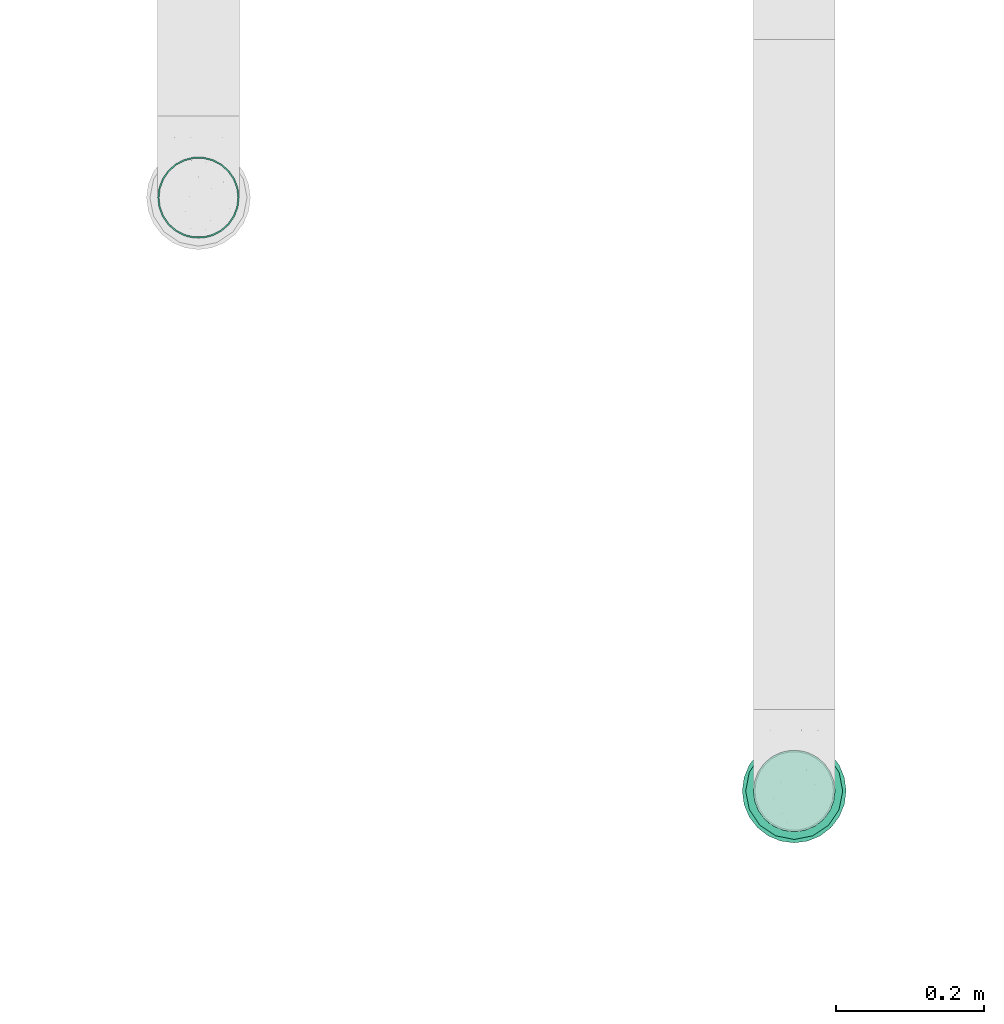
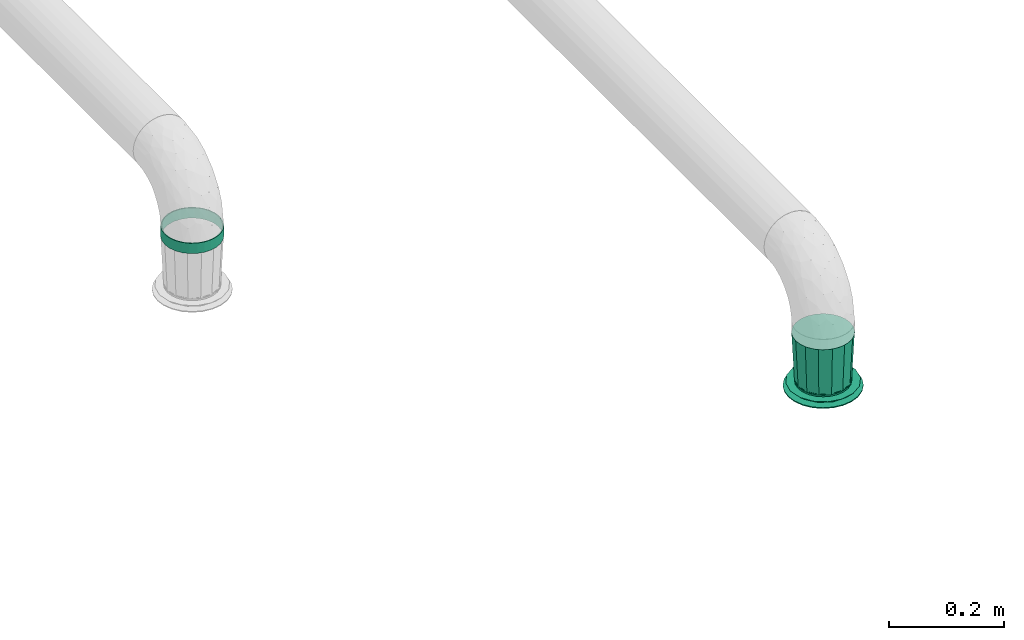
# One storey, part 85 of 123: 1 flow fitting, 1 flow segment, 1 flow terminal.
"""IFC2X3 building model written with IfcOpenShell, lengths in millimetres."""

from ifc_helpers import new_model, entity, si_unit, converted_unit, derived_unit, direction, frame, origin_with_axes, origin_2d_with_axis, place, context, subcontext, project, spatial, hollow_circle, extrude, open_shell, surface_model, source, transform, mapped, material, layer, layer_set, layer_usage, type_object, element, save


model = new_model("IFC2X3")

# Units and contexts
model_context = context("Model", 3, precision=1e-05, world=origin_with_axes(), true_north=direction((0.0, 1.0)))
body_context = subcontext(model_context, "Body", "Model", "MODEL_VIEW")
ifc_project = project(units=[si_unit("AREAUNIT", "SQUARE_METRE"), si_unit("VOLUMEUNIT", "CUBIC_METRE", prefix="DECI"), si_unit("TIMEUNIT", "SECOND"), si_unit("THERMODYNAMICTEMPERATUREUNIT", "DEGREE_CELSIUS"), si_unit("PRESSUREUNIT", "PASCAL"), si_unit("MASSUNIT", "GRAM", prefix="KILO"), si_unit("LENGTHUNIT", "METRE", prefix="MILLI"), si_unit("POWERUNIT", "WATT"), si_unit("ELECTRICCURRENTUNIT", "AMPERE"), si_unit("ELECTRICVOLTAGEUNIT", "VOLT"), derived_unit("VOLUMETRICFLOWRATEUNIT", [(si_unit("VOLUMEUNIT", "CUBIC_METRE", prefix="DECI"), 1), (si_unit("TIMEUNIT", "SECOND"), -1)]), derived_unit("LINEARVELOCITYUNIT", [(si_unit("LENGTHUNIT", "METRE"), 1), (si_unit("TIMEUNIT", "SECOND"), -1)]), derived_unit("MASSDENSITYUNIT", [(si_unit("MASSUNIT", "GRAM", prefix="KILO"), 1), (si_unit("VOLUMEUNIT", "CUBIC_METRE"), -1)]), converted_unit("PLANEANGLEUNIT", "DEGREE", entity("IfcRatioMeasure", 0.01745), si_unit("PLANEANGLEUNIT", "RADIAN"), dimensions=[0, 0, 0, 0, 0, 0, 0])], contexts=[model_context])

# Site, building, storey
site_placement = place(None, origin_with_axes())
site = spatial("IfcSite", under=ifc_project, at=site_placement, CompositionType="ELEMENT")
building_placement = place(site_placement, origin_with_axes())
building = spatial("IfcBuilding", under=site, at=building_placement, Name="mc-building", CompositionType="ELEMENT")
storey_placement = place(building_placement, origin_with_axes())
storey = spatial("IfcBuildingStorey", under=building, at=storey_placement, Name="1. Korrus", CompositionType="ELEMENT", Elevation=0.0)

# Flow segment
ifc_material = material(Name="FZ1")
ifc_layer = layer(ifc_material, 0.0)
ifc_layer_set = layer_set([ifc_layer], Name="FZ1")
ifc_layer_usage = layer_usage(ifc_layer_set, "AXIS1", "POSITIVE", 0.0)
duct_segment_type = type_object("IfcDuctSegmentType", PredefinedType="RIGIDSEGMENT")
shared_shape_1 = source(origin_with_axes(), body_context, "Body", "SweptSolid", [
    extrude(hollow_circle(Radius=55.0, WallThickness=2.0, at=origin_2d_with_axis()), frame((0.0, 0.0, 0.0), z_axis=(1.0, 0.0, 0.0), x_axis=(0.0, 1.0, 0.0)), (0.0, 0.0, 1.0), 21.9),
])
flow_segment_placement = place(storey_placement, frame((18242.77608, 9054.17592, 2325.0), z_axis=(0.0, 1.0, 0.0), x_axis=(0.0, 0.0, -1.0)))
element("IfcFlowSegment", 1, at=flow_segment_placement, inside=storey, type_object=duct_segment_type, material=ifc_layer_usage, context=body_context, shape_type="MappedRepresentation", body=[
    mapped(shared_shape_1, transform((0.0, 0.0, 0.0), scale=1.0)),
])

# Flow terminal
air_terminal_type = type_object("IfcAirTerminalType", Name="100", PredefinedType="NOTDEFINED")
shared_shape_2 = source(origin_with_axes(), body_context, "Body", "SurfaceModel", [
    surface_model("IfcShellBasedSurfaceModel", [(11.2, -70.0, 0.0), (11.2, -67.61481, -18.11733), (11.2, -67.61481, 18.11733), (6.2, -14.64625, -20.15883), (9.2, -22.36867, -22.36867), (6.2, -21.19625, -15.39997), (9.2, 16.375, -28.36233), (6.2, 8.09625, -24.91768), (6.2, 14.64625, -20.15883), (6.2, -8.09625, -24.91768), (9.2, -16.375, -28.36233), (6.2, 21.19625, -15.39997), (9.2, 22.36867, -22.36867), (9.2, -8.1875, -30.55617), (9.2, 8.1875, -30.55617), (9.2, 28.36233, -16.375), (9.2, -28.36233, -16.375), (6.2, 14.64625, 20.15883), (9.2, 22.36867, 22.36867), (6.2, 21.19625, 15.39997), (9.2, -16.375, 28.36233), (6.2, -8.09625, 24.91768), (6.2, -14.64625, 20.15883), (6.2, 8.09625, 24.91768), (9.2, 16.375, 28.36233), (6.2, -21.19625, 15.39997), (9.2, -22.36867, 22.36867), (9.2, 8.1875, 30.55617), (9.2, -8.1875, 30.55617), (9.2, -28.36233, 16.375), (9.2, 28.36233, 16.375), (6.2, -53.11211, -25.57744), (6.2, -36.75472, -46.08897), (6.2, -13.11761, -57.472), (6.2, 13.11761, -57.472), (6.2, 36.75472, -46.08897), (6.2, 53.11211, -25.57744), (0.0, -12.53288, -63.00706), (6.2, 0.0, -57.472), (0.0, -46.3155, -46.3155), (0.0, -35.69063, -53.4148), (0.0, 0.0, -65.5), (6.2, 44.93342, -35.83321), (0.0, 46.3155, -46.3155), (0.0, 35.69063, -53.4148), (6.2, -44.93342, -35.83321), (0.0, 12.53288, -63.00706), (0.0, 25.06576, -60.51411), (6.2, 56.03105, -12.78872), (0.0, 60.51411, -25.06576), (0.0, 63.00706, -12.53288), (0.0, 53.4148, -35.69063), (0.0, -25.06576, -60.51411), (0.0, -63.00706, -12.53288), (0.0, -60.51411, -25.06576), (6.2, -56.03105, -12.78872), (0.0, -53.4148, -35.69063), (6.2, 13.11761, 57.472), (0.0, 12.53288, 63.00706), (6.2, 0.0, 57.472), (6.2, 36.75472, 46.08897), (0.0, 46.3155, 46.3155), (0.0, 35.69063, 53.4148), (0.0, 0.0, 65.5), (6.2, -44.93342, 35.83321), (6.2, -36.75472, 46.08897), (0.0, -46.3155, 46.3155), (0.0, -35.69063, 53.4148), (6.2, 44.93342, 35.83321), (0.0, -12.53288, 63.00706), (0.0, -25.06576, 60.51411), (6.2, -13.11761, 57.472), (6.2, -56.03105, 12.78872), (0.0, -60.51411, 25.06576), (0.0, -63.00706, 12.53288), (0.0, -53.4148, 35.69063), (0.0, 25.06576, 60.51411), (0.0, 63.00706, 12.53288), (0.0, 60.51411, 25.06576), (6.2, 56.03105, 12.78872), (0.0, 53.4148, 35.69063), (-3.1, 43.30127, 25.0), (-3.1, -48.29629, -12.94095), (-3.1, -43.30127, 25.0), (-3.1, 25.0, -43.30127), (-3.1, 48.29629, -12.94095), (-3.1, 35.35534, -35.35534), (-3.1, -35.35534, -35.35534), (-3.1, -25.0, -43.30127), (-43.1, 43.46666, 11.64686), (-3.1, 38.97115, 22.5), (-3.1, 43.46666, 11.64686), (-3.1, 45.0, 0.0), (-43.1, 45.0, 0.0), (-3.1, 31.81981, 31.81981), (-43.1, 38.97115, 22.5), (-43.1, -38.97115, 22.5), (-3.1, -38.97115, 22.5), (-3.1, -31.81981, 31.81981), (-3.1, -43.46666, 11.64686), (-43.1, -43.46666, 11.64686), (-43.1, -45.0, 0.0), (-3.1, -45.0, 0.0), (-43.1, -43.46666, -11.64686), (-3.1, -38.97115, -22.5), (-3.1, -43.46666, -11.64686), (-3.1, -11.64686, -43.46666), (-3.1, -22.5, -38.97115), (-43.1, -22.5, -38.97115), (-3.1, -31.81981, -31.81981), (-43.1, -38.97115, -22.5), (-43.1, 22.5, -38.97115), (-3.1, 22.5, -38.97115), (-3.1, 11.64686, -43.46666), (-43.1, 38.97115, -22.5), (-3.1, 38.97115, -22.5), (-3.1, 31.81981, -31.81981), (-3.1, 43.46666, -11.64686), (-43.1, 43.46666, -11.64686), (11.2, -49.49747, -49.49747), (11.2, -35.0, -60.62178), (11.2, -18.11733, -67.61481), (11.2, 67.61481, 18.11733), (11.2, -60.62178, -35.0), (11.2, 18.11733, -67.61481), (11.2, 35.0, -60.62178), (11.2, 0.0, -70.0), (11.2, 60.62178, -35.0), (11.2, 67.61481, -18.11733), (11.2, 49.49747, -49.49747), (11.2, -49.49747, 49.49747), (11.2, -60.62178, 35.0), (11.2, -35.0, 60.62178), (11.2, -18.11733, 67.61481), (11.2, 0.0, 70.0), (11.2, 60.62178, 35.0), (11.2, 49.49747, 49.49747), (11.2, 70.0, 0.0), (11.2, 35.0, 60.62178), (11.2, 18.11733, 67.61481), (9.2, -49.49747, 49.49747), (9.2, -35.0, 60.62178), (9.2, -18.11733, 67.61481), (9.2, -67.61481, 18.11733), (9.2, -70.0, 0.0), (9.2, -60.62178, 35.0), (9.2, 67.61481, 18.11733), (9.2, 35.0, 60.62178), (9.2, 18.11733, 67.61481), (9.2, 0.0, 70.0), (9.2, 60.62178, 35.0), (9.2, 49.49747, 49.49747), (9.2, -67.61481, -18.11733), (9.2, -49.49747, -49.49747), (9.2, -60.62178, -35.0), (9.2, -18.11733, -67.61481), (9.2, 70.0, 0.0), (9.2, -35.0, -60.62178), (9.2, 0.0, -70.0), (9.2, 60.62178, -35.0), (9.2, 49.49747, -49.49747), (9.2, 67.61481, -18.11733), (9.2, 35.0, -60.62178), (9.2, 18.11733, -67.61481), (9.2, -32.75, 0.0), (9.2, 0.0, 32.75), (9.2, 32.75, 0.0), (9.2, 0.0, -32.75), (6.2, 26.2, 0.0), (6.2, -26.2, 0.0), (9.2, -31.06579, -6.28555), (6.2, -23.69812, -7.69999), (6.2, 23.69812, -7.69999), (9.2, 31.06579, -6.28555), (6.2, 0.0, -24.91768), (9.2, 31.06579, 6.28555), (6.2, 23.69812, 7.69999), (6.2, -23.69812, 7.69999), (9.2, -31.06579, 6.28555), (6.2, 0.0, 24.91768), (6.2, 53.11211, 25.57744), (6.2, 58.95, 0.0), (6.2, -53.11211, 25.57744), (6.2, -58.95, 0.0), (0.0, 65.5, 0.0), (0.0, -65.5, 0.0), (6.2, -24.93616, -51.78048), (6.2, 24.93616, -51.78048), (6.2, 24.93616, 51.78048), (6.2, -24.93616, 51.78048), (-3.1, 0.0, 50.0), (-3.1, 35.35534, 35.35534), (-3.1, -12.94095, 48.29629), (-3.1, -25.0, 43.30127), (-3.1, -35.35534, 35.35534), (-3.1, 25.0, 43.30127), (-3.1, 12.94095, 48.29629), (-3.1, 48.29629, 12.94095), (-3.1, 50.0, 0.0), (-3.1, -50.0, 0.0), (-3.1, -48.29629, 12.94095), (-3.1, -43.30127, -25.0), (-3.1, -12.94095, -48.29629), (-3.1, 0.0, -50.0), (-3.1, 43.30127, -25.0), (-3.1, 12.94095, -48.29629), (0.0, -12.94095, -48.29629), (0.0, 0.0, -50.0), (0.0, -25.0, -43.30127), (0.0, -35.35534, -35.35534), (0.0, -48.29629, -12.94095), (0.0, 25.0, -43.30127), (0.0, -43.30127, -25.0), (0.0, 43.30127, 25.0), (0.0, 12.94095, -48.29629), (0.0, 43.30127, -25.0), (0.0, 48.29629, -12.94095), (0.0, 35.35534, -35.35534), (0.0, 50.0, 0.0), (0.0, -50.0, 0.0), (0.0, -48.29629, 12.94095), (0.0, -43.30127, 25.0), (0.0, -35.35534, 35.35534), (0.0, -12.94095, 48.29629), (0.0, -25.0, 43.30127), (0.0, 35.35534, 35.35534), (0.0, 0.0, 50.0), (0.0, 48.29629, 12.94095), (0.0, 25.0, 43.30127), (0.0, 12.94095, 48.29629), (-43.1, -22.5, 38.97115), (-43.1, -11.64686, 43.46666), (-43.1, 0.0, 45.0), (-43.1, 11.64686, 43.46666), (-43.1, -31.81981, 31.81981), (-43.1, 31.81981, 31.81981), (-43.1, 22.5, 38.97115), (-43.1, -31.81981, -31.81981), (-43.1, 31.81981, -31.81981), (-43.1, -11.64686, -43.46666), (-43.1, 11.64686, -43.46666), (-43.1, 0.0, -45.0), (-3.1, 0.0, -45.0), (-3.1, 0.0, 45.0), (-3.1, -22.5, 38.97115), (-3.1, -11.64686, 43.46666), (-3.1, 11.64686, 43.46666), (-3.1, 22.5, 38.97115)], [open_shell([[[0, 1, 2]], [[3, 4, 5]], [[6, 7, 8]], [[3, 9, 10]], [[4, 3, 10]], [[11, 12, 8]], [[13, 10, 9]], [[7, 6, 14]], [[6, 8, 12]], [[12, 11, 15]], [[16, 5, 4]], [[17, 18, 19]], [[20, 21, 22]], [[17, 23, 24]], [[18, 17, 24]], [[25, 26, 22]], [[27, 24, 23]], [[21, 20, 28]], [[20, 22, 26]], [[26, 25, 29]], [[30, 19, 18]], [[31, 32, 33]], [[34, 35, 36]], [[33, 37, 38]], [[32, 39, 40]], [[41, 38, 37]], [[42, 35, 43]], [[44, 43, 35]], [[39, 32, 45]], [[46, 47, 34]], [[48, 49, 50]], [[38, 46, 34]], [[42, 43, 51]], [[33, 52, 37]], [[53, 54, 55]], [[46, 38, 41]], [[56, 39, 45]], [[57, 58, 59]], [[60, 61, 62]], [[63, 59, 58]], [[64, 65, 66]], [[67, 66, 65]], [[61, 60, 68]], [[69, 70, 71]], [[72, 73, 74]], [[59, 69, 71]], [[64, 66, 75]], [[57, 76, 58]], [[77, 78, 79]], [[69, 59, 63]], [[80, 61, 68]], [[81, 82, 83]], [[84, 85, 86]], [[87, 82, 88]], [[89, 90, 91]], [[91, 92, 93]], [[94, 90, 95]], [[96, 97, 98]], [[99, 97, 100]], [[101, 102, 99]], [[103, 104, 105]], [[105, 102, 101]], [[106, 107, 108]], [[109, 104, 110]], [[111, 112, 113]], [[114, 115, 116]], [[117, 115, 118]], [[93, 92, 117]], [[119, 120, 121]], [[1, 119, 121]], [[122, 1, 121]], [[123, 119, 1]], [[124, 122, 121]], [[125, 122, 124]], [[121, 126, 124]], [[127, 128, 129]], [[129, 128, 122]], [[129, 122, 125]], [[130, 131, 2]], [[132, 130, 2]], [[122, 133, 2]], [[132, 2, 133]], [[134, 133, 122]], [[135, 136, 122]], [[122, 128, 137]], [[136, 138, 122]], [[139, 122, 138]], [[122, 139, 134]], [[2, 1, 122]], [[140, 141, 142]], [[143, 140, 142]], [[142, 144, 143]], [[145, 140, 143]], [[146, 144, 142]], [[147, 146, 148]], [[149, 148, 146]], [[150, 146, 151]], [[147, 151, 146]], [[146, 142, 149]], [[146, 152, 144]], [[153, 154, 152]], [[155, 153, 152]], [[146, 156, 155]], [[157, 153, 155]], [[158, 155, 156]], [[159, 160, 161]], [[156, 161, 160]], [[160, 162, 156]], [[163, 156, 162]], [[163, 158, 156]], [[152, 146, 155]], [[156, 128, 161]], [[161, 127, 159]], [[162, 160, 125]], [[129, 160, 159]], [[163, 162, 124]], [[128, 127, 161]], [[156, 137, 128]], [[162, 125, 124]], [[125, 160, 129]], [[159, 127, 129]], [[163, 124, 126]], [[126, 158, 163]], [[158, 121, 155]], [[155, 120, 157]], [[154, 153, 123]], [[119, 153, 157]], [[152, 154, 1]], [[120, 119, 157]], [[155, 121, 120]], [[152, 1, 0]], [[1, 154, 123]], [[153, 119, 123]], [[152, 0, 144]], [[126, 121, 158]], [[144, 2, 143]], [[143, 131, 145]], [[141, 140, 132]], [[130, 140, 145]], [[142, 141, 133]], [[2, 131, 143]], [[144, 0, 2]], [[141, 132, 133]], [[132, 140, 130]], [[145, 131, 130]], [[142, 133, 134]], [[134, 149, 142]], [[149, 139, 148]], [[148, 138, 147]], [[150, 151, 135]], [[136, 151, 147]], [[146, 150, 122]], [[138, 136, 147]], [[148, 139, 138]], [[146, 122, 137]], [[122, 150, 135]], [[151, 136, 135]], [[146, 137, 156]], [[134, 139, 149]], [[30, 24, 164]], [[24, 20, 164]], [[165, 20, 24]], [[164, 20, 29]], [[166, 30, 16]], [[16, 6, 166]], [[167, 6, 10]], [[30, 164, 16]], [[10, 6, 16]], [[6, 15, 166]], [[21, 19, 11]], [[23, 19, 21]], [[11, 19, 168]], [[7, 25, 21]], [[7, 5, 169]], [[21, 11, 7]], [[9, 5, 7]], [[169, 25, 7]], [[170, 164, 169]], [[170, 171, 16]], [[11, 172, 15]], [[172, 168, 173]], [[174, 13, 9]], [[166, 173, 168]], [[172, 173, 15]], [[169, 171, 170]], [[5, 16, 171]], [[167, 174, 14]], [[174, 167, 13]], [[14, 174, 7]], [[175, 166, 168]], [[175, 176, 30]], [[25, 177, 29]], [[177, 169, 178]], [[179, 27, 23]], [[164, 178, 169]], [[177, 178, 29]], [[168, 176, 175]], [[19, 30, 176]], [[165, 179, 28]], [[179, 165, 27]], [[28, 179, 21]], [[180, 60, 57]], [[181, 180, 65]], [[65, 57, 71]], [[180, 57, 65]], [[65, 182, 181]], [[182, 36, 181]], [[183, 34, 36]], [[31, 34, 183]], [[31, 33, 34]], [[182, 183, 36]], [[70, 63, 49]], [[70, 73, 66]], [[49, 63, 184]], [[78, 76, 61]], [[76, 78, 184]], [[184, 63, 76]], [[73, 70, 49]], [[39, 54, 185]], [[41, 39, 185]], [[52, 39, 41]], [[43, 185, 49]], [[185, 43, 47]], [[185, 47, 41]], [[73, 49, 185]], [[55, 54, 31]], [[31, 54, 56]], [[52, 186, 40]], [[53, 55, 183]], [[56, 45, 31]], [[185, 53, 183]], [[32, 40, 186]], [[33, 186, 52]], [[44, 35, 187]], [[49, 36, 51]], [[34, 47, 187]], [[42, 51, 36]], [[187, 47, 44]], [[49, 48, 36]], [[48, 50, 181]], [[184, 181, 50]], [[79, 78, 180]], [[180, 78, 80]], [[76, 188, 62]], [[77, 79, 181]], [[80, 68, 180]], [[184, 77, 181]], [[60, 62, 188]], [[57, 188, 76]], [[67, 65, 189]], [[73, 182, 75]], [[71, 70, 189]], [[64, 75, 182]], [[189, 70, 67]], [[73, 72, 182]], [[72, 74, 183]], [[185, 183, 74]], [[190, 191, 192]], [[193, 192, 194]], [[83, 192, 81]], [[194, 192, 83]], [[195, 191, 196]], [[191, 190, 196]], [[197, 198, 81]], [[81, 192, 191]], [[198, 84, 81]], [[199, 200, 83]], [[81, 88, 82]], [[201, 82, 87]], [[88, 81, 202]], [[81, 203, 202]], [[204, 86, 85]], [[205, 203, 84]], [[84, 198, 85]], [[81, 84, 203]], [[199, 83, 82]], [[206, 207, 208]], [[209, 208, 210]], [[210, 208, 211]], [[212, 209, 210]], [[210, 211, 213]], [[214, 211, 207]], [[211, 208, 207]], [[215, 216, 217]], [[211, 217, 216]], [[216, 218, 211]], [[219, 210, 220]], [[221, 210, 213]], [[222, 221, 223]], [[213, 223, 221]], [[224, 222, 223]], [[223, 225, 226]], [[227, 213, 218]], [[218, 213, 211]], [[228, 229, 225]], [[223, 213, 225]], [[226, 225, 229]], [[221, 220, 210]], [[199, 220, 200]], [[200, 221, 83]], [[193, 194, 224]], [[222, 194, 83]], [[192, 193, 223]], [[220, 221, 200]], [[199, 219, 220]], [[193, 224, 223]], [[224, 194, 222]], [[83, 221, 222]], [[192, 223, 226]], [[226, 190, 192]], [[190, 229, 196]], [[196, 228, 195]], [[81, 191, 213]], [[225, 191, 195]], [[197, 81, 227]], [[228, 225, 195]], [[196, 229, 228]], [[197, 227, 218]], [[227, 81, 213]], [[191, 225, 213]], [[197, 218, 198]], [[226, 229, 190]], [[198, 216, 85]], [[85, 215, 204]], [[84, 86, 211]], [[217, 86, 204]], [[205, 84, 214]], [[216, 215, 85]], [[198, 218, 216]], [[84, 211, 214]], [[211, 86, 217]], [[204, 215, 217]], [[205, 214, 207]], [[207, 203, 205]], [[203, 206, 202]], [[202, 208, 88]], [[201, 87, 212]], [[209, 87, 88]], [[82, 201, 210]], [[208, 209, 88]], [[202, 206, 208]], [[82, 210, 219]], [[210, 201, 212]], [[87, 209, 212]], [[82, 219, 199]], [[207, 206, 203]], [[230, 231, 232]], [[230, 232, 233]], [[230, 100, 96]], [[234, 230, 96]], [[100, 230, 233]], [[235, 89, 236]], [[100, 233, 236]], [[95, 89, 235]], [[118, 89, 93]], [[118, 236, 89]], [[118, 100, 236]], [[110, 103, 101]], [[237, 110, 101]], [[238, 108, 101]], [[237, 101, 108]], [[239, 108, 238]], [[114, 238, 118]], [[238, 101, 118]], [[240, 241, 111]], [[238, 111, 241]], [[238, 241, 239]], [[100, 118, 101]], [[106, 242, 107]], [[107, 112, 109]], [[102, 105, 104]], [[112, 104, 109]], [[92, 104, 117]], [[113, 112, 242]], [[112, 107, 242]], [[115, 117, 116]], [[112, 116, 117]], [[112, 117, 104]], [[92, 102, 104]], [[97, 99, 243]], [[98, 97, 244]], [[243, 245, 244]], [[97, 243, 244]], [[246, 243, 99]], [[90, 94, 91]], [[92, 91, 247]], [[94, 247, 91]], [[247, 99, 92]], [[247, 246, 99]], [[102, 92, 99]], [[101, 99, 100]], [[100, 97, 96]], [[230, 234, 244]], [[98, 234, 96]], [[231, 230, 245]], [[245, 230, 244]], [[244, 234, 98]], [[245, 243, 231]], [[243, 232, 231]], [[236, 233, 246]], [[236, 247, 235]], [[89, 95, 90]], [[94, 95, 235]], [[93, 89, 91]], [[232, 246, 233]], [[246, 247, 236]], [[243, 246, 232]], [[247, 94, 235]], [[93, 117, 118]], [[118, 115, 114]], [[111, 238, 112]], [[116, 238, 114]], [[240, 111, 113]], [[112, 238, 116]], [[240, 113, 242]], [[242, 241, 240]], [[108, 239, 106]], [[108, 107, 237]], [[103, 110, 104]], [[109, 110, 237]], [[101, 103, 105]], [[241, 106, 239]], [[242, 106, 241]], [[107, 109, 237]]])]),
])
flow_terminal_placement = place(storey_placement, frame((19046.0369, 8254.17592, 2200.0), z_axis=(0.0, 1.0, 0.0), x_axis=(0.0, 0.0, -1.0)))
element("IfcFlowTerminal", 2, at=flow_terminal_placement, inside=storey, type_object=air_terminal_type, Name="100", context=body_context, shape_type="MappedRepresentation", body=[
    mapped(shared_shape_2, transform((0.0, 0.0, 0.0), scale=1.0)),
])

# Flow fitting
duct_fitting_type = type_object("IfcDuctFittingType", PredefinedType="TRANSITION")
shared_shape_3 = source(origin_with_axes(), body_context, "Body", "SurfaceModel", [
    surface_model("IfcShellBasedSurfaceModel", [(100.0, -55.0, 0.0), (100.0, -12.23865, 53.62104), (100.0, -34.29194, 43.00073), (100.0, 49.55329, 23.86361), (100.0, 34.29194, 43.00073), (100.0, 49.55329, -23.86361), (0.0, -45.04844, -21.69419), (0.0, -50.0, 0.0), (0.0, -45.04844, 21.69419), (0.0, 31.17449, 39.09157), (0.0, 45.04844, 21.69419), (0.0, 50.0, 0.0), (98.0, 47.63139, 27.5), (98.0, 0.0, 55.0), (98.0, 38.89087, 38.89087), (98.0, -38.89087, 38.89087), (98.0, -47.63139, 27.5), (100.0, 12.23865, 53.62104), (100.0, -49.55329, 23.86361), (100.0, 55.0, 0.0), (100.0, 12.23865, -53.62104), (100.0, 34.29194, -43.00073), (100.0, -49.55329, -23.86361), (100.0, -34.29194, -43.00073), (100.0, -12.23865, -53.62104), (0.0, -31.17449, 39.09157), (0.0, -11.12605, 48.7464), (0.0, 11.12605, 48.7464), (0.0, -31.17449, -39.09157), (0.0, 11.12605, -48.7464), (0.0, -11.12605, -48.7464), (0.0, 45.04844, -21.69419), (0.0, 31.17449, -39.09157), (0.0, 47.52422, -10.84709), (0.0, 38.11147, -30.39288), (100.0, 41.92261, -33.43217), (100.0, -41.92261, -33.43217), (0.0, -38.11147, -30.39288), (100.0, 23.2653, -48.31088), (0.0, 21.15027, -43.91899), (100.0, 52.32388, -11.72483), (0.0, 0.0, -48.7464), (100.0, 0.0, -53.62104), (0.0, -21.15027, -43.91899), (100.0, -23.2653, -48.31088), (0.0, -47.52422, -10.84709), (100.0, -52.32388, -11.72483), (0.0, -47.52422, 10.84709), (0.0, -38.11147, 30.39288), (100.0, -41.92261, 33.43217), (100.0, 41.92261, 33.43217), (0.0, 38.11147, 30.39288), (100.0, -23.2653, 48.31088), (0.0, -21.15027, 43.91899), (100.0, -52.32388, 11.72483), (0.0, 0.0, 48.7464), (100.0, 0.0, 53.62104), (0.0, 21.15027, 43.91899), (100.0, 23.2653, 48.31088), (0.0, 47.52422, 10.84709), (100.0, 52.32388, 11.72483), (100.0, -14.23505, -53.12592), (100.0, 0.0, -55.0), (100.0, -27.5, -47.63139), (100.0, 27.5, -47.63139), (100.0, -38.89087, -38.89087), (100.0, -53.12592, -14.23505), (100.0, -47.63139, -27.5), (100.0, -47.63139, 27.5), (100.0, 14.23505, -53.12592), (100.0, 38.89087, -38.89087), (100.0, 47.63139, -27.5), (100.0, 47.63139, 27.5), (100.0, 53.12592, -14.23505), (100.0, -53.12592, 14.23505), (100.0, -38.89087, 38.89087), (100.0, -27.5, 47.63139), (100.0, 0.0, 55.0), (100.0, -14.23505, 53.12592), (100.0, 53.12592, 14.23505), (100.0, 38.89087, 38.89087), (100.0, 27.5, 47.63139), (100.0, 14.23505, 53.12592), (98.0, -27.5, 47.63139), (98.0, -14.23505, 53.12592), (98.0, -53.12592, -14.23505), (98.0, 14.23505, 53.12592), (98.0, 27.5, 47.63139), (98.0, 53.12592, 14.23505), (98.0, 55.0, 0.0), (98.0, -47.63139, -27.5), (98.0, -53.12592, 14.23505), (98.0, 27.5, -47.63139), (98.0, -27.5, -47.63139), (98.0, -38.89087, -38.89087), (98.0, 0.0, -55.0), (98.0, -14.23505, -53.12592), (98.0, 38.89087, -38.89087), (98.0, 47.63139, -27.5), (98.0, 53.12592, -14.23505), (98.0, 14.23505, -53.12592), (98.0, -55.0, 0.0), (0.0, 0.0, 50.0), (0.0, 35.35534, 35.35534), (0.0, -12.94095, 48.29629), (0.0, -25.0, 43.30127), (0.0, -35.35534, 35.35534), (0.0, -48.29629, 12.94095), (0.0, -43.30127, 25.0), (0.0, 25.0, 43.30127), (0.0, 12.94095, 48.29629), (0.0, 43.30127, 25.0), (0.0, 48.29629, 12.94095), (0.0, 25.0, -43.30127), (0.0, 48.29629, -12.94095), (0.0, -48.29629, -12.94095), (0.0, -43.30127, -25.0), (0.0, -12.94095, -48.29629), (0.0, -25.0, -43.30127), (0.0, -35.35534, -35.35534), (0.0, 43.30127, -25.0), (0.0, 35.35534, -35.35534), (0.0, 12.94095, -48.29629), (0.0, 0.0, -50.0), (2.0, -35.35534, -35.35534), (2.0, -25.0, -43.30127), (2.0, -12.94095, -48.29629), (2.0, -43.30127, -25.0), (2.0, 0.0, -50.0), (2.0, -48.29629, -12.94095), (2.0, -50.0, 0.0), (2.0, 12.94095, -48.29629), (2.0, 25.0, -43.30127), (2.0, 43.30127, -25.0), (2.0, 48.29629, -12.94095), (2.0, 35.35534, -35.35534), (2.0, -48.29629, 12.94095), (2.0, -35.35534, 35.35534), (2.0, -43.30127, 25.0), (2.0, 35.35534, 35.35534), (2.0, -12.94095, 48.29629), (2.0, -25.0, 43.30127), (2.0, 0.0, 50.0), (2.0, 43.30127, 25.0), (2.0, 48.29629, 12.94095), (2.0, 50.0, 0.0), (2.0, 25.0, 43.30127), (2.0, 12.94095, 48.29629)], [open_shell([[[0, 1, 2]], [[3, 4, 5]], [[6, 7, 8]], [[9, 10, 11]], [[12, 13, 14]], [[15, 13, 16]], [[0, 4, 17]], [[2, 18, 0]], [[1, 0, 17]], [[3, 5, 19]], [[20, 21, 5]], [[22, 20, 5]], [[22, 5, 0]], [[22, 23, 24]], [[22, 24, 20]], [[4, 0, 5]], [[8, 25, 6]], [[6, 25, 26]], [[6, 26, 27]], [[11, 27, 9]], [[28, 6, 29]], [[30, 28, 29]], [[31, 6, 11]], [[31, 32, 29]], [[31, 29, 6]], [[27, 11, 6]], [[31, 33, 5]], [[34, 35, 32]], [[36, 22, 6]], [[36, 37, 23]], [[38, 29, 39]], [[33, 40, 5]], [[33, 11, 40]], [[19, 40, 11]], [[32, 21, 39]], [[32, 35, 21]], [[34, 31, 35]], [[30, 41, 42]], [[28, 43, 44]], [[42, 41, 20]], [[7, 45, 46]], [[38, 39, 21]], [[46, 0, 7]], [[6, 37, 36]], [[38, 20, 29]], [[43, 30, 24]], [[42, 24, 30]], [[28, 23, 37]], [[6, 22, 45]], [[35, 31, 5]], [[44, 43, 24]], [[20, 41, 29]], [[46, 45, 22]], [[44, 23, 28]], [[8, 47, 18]], [[48, 49, 25]], [[50, 3, 10]], [[50, 51, 4]], [[52, 26, 53]], [[47, 54, 18]], [[47, 7, 54]], [[0, 54, 7]], [[25, 2, 53]], [[25, 49, 2]], [[48, 8, 49]], [[27, 55, 56]], [[9, 57, 58]], [[56, 55, 1]], [[11, 59, 60]], [[52, 53, 2]], [[60, 19, 11]], [[10, 51, 50]], [[52, 1, 26]], [[57, 27, 17]], [[56, 17, 27]], [[9, 4, 51]], [[10, 3, 59]], [[49, 8, 18]], [[58, 57, 17]], [[1, 55, 26]], [[60, 59, 3]], [[58, 4, 9]], [[61, 62, 63]], [[63, 64, 65]], [[66, 67, 68]], [[65, 64, 67]], [[67, 64, 68]], [[69, 64, 62]], [[64, 63, 62]], [[70, 71, 64]], [[72, 64, 71]], [[71, 73, 19]], [[74, 0, 66]], [[72, 68, 64]], [[75, 68, 76]], [[77, 78, 76]], [[72, 76, 68]], [[76, 72, 77]], [[79, 72, 19]], [[19, 72, 71]], [[80, 81, 77]], [[77, 72, 80]], [[82, 77, 81]], [[74, 66, 68]], [[83, 84, 13]], [[15, 83, 13]], [[12, 16, 13]], [[16, 12, 85]], [[86, 87, 13]], [[87, 14, 13]], [[88, 89, 12]], [[89, 90, 12]], [[91, 16, 85]], [[90, 85, 12]], [[89, 92, 90]], [[93, 94, 95]], [[95, 94, 90]], [[96, 93, 95]], [[97, 92, 98]], [[98, 89, 99]], [[100, 95, 92]], [[92, 89, 98]], [[90, 92, 95]], [[101, 91, 85]], [[89, 73, 99]], [[99, 71, 98]], [[92, 97, 64]], [[70, 97, 98]], [[100, 92, 69]], [[73, 71, 99]], [[89, 19, 73]], [[92, 64, 69]], [[64, 97, 70]], [[98, 71, 70]], [[100, 69, 62]], [[62, 95, 100]], [[95, 61, 96]], [[96, 63, 93]], [[90, 94, 67]], [[65, 94, 93]], [[85, 90, 66]], [[63, 65, 93]], [[96, 61, 63]], [[85, 66, 0]], [[66, 90, 67]], [[94, 65, 67]], [[85, 0, 101]], [[62, 61, 95]], [[101, 74, 91]], [[91, 68, 16]], [[83, 15, 76]], [[75, 15, 16]], [[84, 83, 78]], [[74, 68, 91]], [[101, 0, 74]], [[83, 76, 78]], [[76, 15, 75]], [[16, 68, 75]], [[84, 78, 77]], [[77, 13, 84]], [[13, 82, 86]], [[86, 81, 87]], [[12, 14, 72]], [[80, 14, 87]], [[88, 12, 79]], [[81, 80, 87]], [[86, 82, 81]], [[88, 79, 19]], [[79, 12, 72]], [[14, 80, 72]], [[88, 19, 89]], [[77, 82, 13]], [[102, 103, 104]], [[105, 104, 106]], [[107, 108, 106]], [[103, 106, 104]], [[106, 103, 107]], [[109, 103, 110]], [[103, 102, 110]], [[111, 112, 103]], [[113, 103, 112]], [[112, 11, 114]], [[107, 103, 113]], [[113, 115, 107]], [[116, 115, 117]], [[117, 118, 119]], [[116, 117, 119]], [[117, 115, 113]], [[120, 121, 114]], [[113, 114, 121]], [[113, 122, 117]], [[113, 112, 114]], [[117, 122, 123]], [[7, 107, 115]], [[124, 125, 126]], [[127, 124, 126]], [[128, 129, 126]], [[127, 126, 129]], [[130, 129, 128]], [[131, 132, 128]], [[132, 130, 128]], [[133, 134, 135]], [[132, 135, 134]], [[132, 134, 130]], [[134, 136, 130]], [[137, 138, 136]], [[137, 136, 139]], [[140, 137, 139]], [[141, 137, 140]], [[142, 140, 139]], [[143, 139, 144]], [[144, 134, 145]], [[146, 147, 139]], [[139, 136, 144]], [[139, 147, 142]], [[136, 134, 144]], [[11, 134, 114]], [[114, 133, 120]], [[113, 121, 132]], [[135, 121, 120]], [[122, 113, 131]], [[134, 133, 114]], [[11, 145, 134]], [[113, 132, 131]], [[132, 121, 135]], [[120, 133, 135]], [[122, 131, 128]], [[128, 123, 122]], [[123, 126, 117]], [[117, 125, 118]], [[116, 119, 127]], [[124, 119, 118]], [[115, 116, 129]], [[125, 124, 118]], [[117, 126, 125]], [[115, 129, 130]], [[129, 116, 127]], [[119, 124, 127]], [[115, 130, 7]], [[128, 126, 123]], [[7, 136, 107]], [[107, 138, 108]], [[105, 106, 141]], [[137, 106, 108]], [[104, 105, 140]], [[136, 138, 107]], [[7, 130, 136]], [[105, 141, 140]], [[141, 106, 137]], [[108, 138, 137]], [[104, 140, 142]], [[142, 102, 104]], [[102, 147, 110]], [[110, 146, 109]], [[111, 103, 143]], [[139, 103, 109]], [[112, 111, 144]], [[146, 139, 109]], [[110, 147, 146]], [[112, 144, 145]], [[144, 111, 143]], [[103, 139, 143]], [[112, 145, 11]], [[142, 147, 102]]])]),
])
flow_fitting_placement = place(storey_placement, frame((19046.0369, 8254.17592, 2203.1), z_axis=(0.0, 1.0, 0.0), x_axis=(0.0, 0.0, 1.0)))
element("IfcFlowFitting", 3, at=flow_fitting_placement, inside=storey, type_object=duct_fitting_type, context=body_context, shape_type="MappedRepresentation", body=[
    mapped(shared_shape_3, transform((0.0, 0.0, 0.0), scale=1.0)),
])

save(model, "model.ifc")
